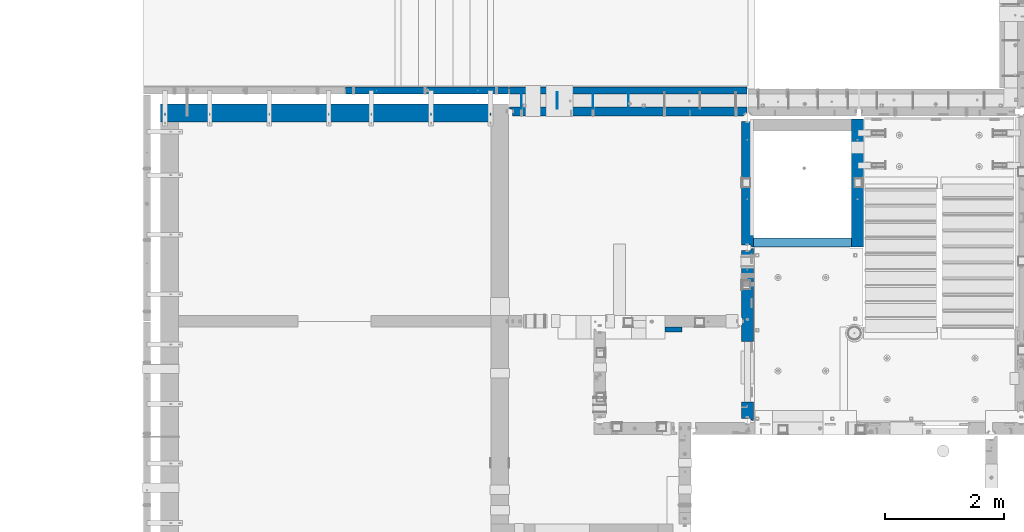
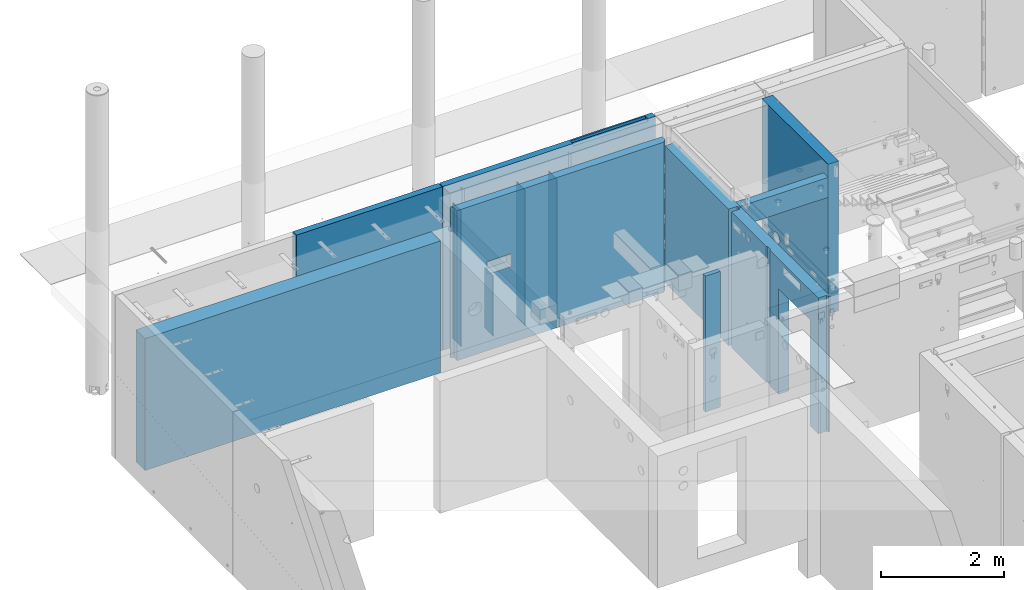
# One storey, part 175 of 264: 13 walls, 6 elements without a shape of their own.
"""IFC2X3 building model written with IfcOpenShell, lengths in millimetres."""

from ifc_helpers import new_model, si_unit, frame, origin_with_axes, place, context, subcontext, project, spatial, faceted_brep, material, type_object, element, aggregate, save


model = new_model("IFC2X3")

# Units and contexts
model_context = context("Model", 3, precision=1e-05, world=origin_with_axes())
body_context = subcontext(model_context, "Body", "Model", "MODEL_VIEW")
ifc_project = project(units=[si_unit("LENGTHUNIT", "METRE", prefix="MILLI"), si_unit("AREAUNIT", "SQUARE_METRE"), si_unit("VOLUMEUNIT", "CUBIC_METRE"), si_unit("MASSUNIT", "GRAM", prefix="KILO"), si_unit("TIMEUNIT", "SECOND"), si_unit("PLANEANGLEUNIT", "RADIAN"), si_unit("SOLIDANGLEUNIT", "STERADIAN"), si_unit("THERMODYNAMICTEMPERATUREUNIT", "DEGREE_CELSIUS"), si_unit("LUMINOUSINTENSITYUNIT", "LUMEN")], contexts=[model_context])

# Site, building, storey
site_placement = place(None, origin_with_axes())
site = spatial("IfcSite", under=ifc_project, at=site_placement, CompositionType="ELEMENT")
building_placement = place(site_placement, origin_with_axes())
building = spatial("IfcBuilding", under=site, at=building_placement, CompositionType="ELEMENT")
storey_placement = place(building_placement, origin_with_axes())
storey = spatial("IfcBuildingStorey", under=building, at=storey_placement, Name="K", CompositionType="ELEMENT", Elevation=0.0)

# Assembly, walls
assembly_1_placement = place(storey_placement, origin_with_axes())
assembly_1 = element("IfcElementAssembly", 1, at=assembly_1_placement, inside=storey, AssemblyPlace="NOTDEFINED", PredefinedType="REINFORCEMENT_UNIT")
ifc_material_1 = material(Name="CONCRETE/C25/30")
wall_type_1 = type_object("IfcWallType", PredefinedType="NOTDEFINED")
wall_1_placement = place(assembly_1_placement, frame((17710.0, 18214.9992663657, 80112.5), z_axis=(0.0, 0.0, 1.0), x_axis=(0.0, 1.0, 0.0)))
wall_1 = element("IfcWall", 2, at=wall_1_placement, type_object=wall_type_1, material=ifc_material_1, context=body_context, shape_type="Brep", body=[
    faceted_brep([(2120.00073363433, -57.0000000000036, 1357.5), (2120.00073363433, -57.0000000000036, -1357.5), (2120.00073363433, 100.0, -1357.5), (2120.00073363433, 100.0, 1357.5), (2165.00073363433, -70.0000000000036, 1357.5), (2165.00073363433, -70.0000000000036, -1357.5), (45.0, 100.0, 1357.5), (45.0, 100.0, -1357.5), (45.0, -57.0, -1357.5), (45.0, -57.0, 1357.5), (15.0, -70.0, 1357.5), (15.0, -70.0000000000036, -1357.5), (15.0, -100.0, -1357.5), (15.0, -100.0, 1357.5), (2165.00073363433, -100.0, -1357.5), (2165.00073363433, -100.0, 1357.5)], [[[0, 1, 2, 3]], [[4, 5, 1, 0]], [[6, 7, 8, 9]], [[10, 9, 8, 11]], [[12, 13, 10, 11]], [[13, 12, 14, 15]], [[3, 6, 9, 10, 13, 15, 4, 0]], [[7, 6, 3, 2]], [[14, 12, 11, 8, 7, 2, 1, 5]], [[15, 14, 5, 4]]]),
])
wall_type_2 = type_object("IfcWallType", PredefinedType="NOTDEFINED")
wall_2_placement = place(assembly_1_placement, frame((19559.999681647, 18229.9992663657, 80242.5), z_axis=(0.0, 0.0, 1.0), x_axis=(0.0, 1.0, 0.0)))
wall_2 = element("IfcWall", 3, at=wall_2_placement, type_object=wall_type_2, material=ifc_material_1, context=body_context, shape_type="Brep", body=[
    faceted_brep([(1766.59369624284, -100.0, -1008.38190451026), (1766.59369624284, 100.0, -1008.38190451026), (1756.60365399238, 100.0, -1032.5), (1756.60365399238, -100.0, -1032.5), (1740.71179173259, 100.0, -1053.21067811866), (1740.71179173259, -100.0, -1053.21067811866), (1720.00111361394, 100.0, -1069.10254037844), (1720.00111361394, -100.0, -1069.10254037844), (1695.88301812419, 100.0, -1079.0925826289), (1695.88301812419, -100.0, -1079.0925826289), (1670.00111361394, 100.0, -1082.5), (1670.00111361394, -100.0, -1082.5), (1644.11920910368, 100.0, -1079.0925826289), (1644.11920910368, -100.0, -1079.0925826289), (1620.00111361394, 100.0, -1069.10254037844), (1620.00111361394, -100.0, -1069.10254037844), (1599.29043549528, 100.0, -1053.21067811866), (1599.29043549528, -100.0, -1053.21067811866), (1583.39857323549, 100.0, -1032.5), (1583.39857323549, -100.0, -1032.5), (1573.40853098503, 100.0, -1008.38190451026), (1573.40853098503, -100.0, -1008.38190451026), (1570.00111361394, 100.0, -982.5), (1570.00111361394, -100.0, -982.5), (1573.40853098503, 100.0, -956.618095489743), (1573.40853098503, -100.0, -956.618095489743), (1583.39857323549, 100.0, -932.5), (1583.39857323549, -100.0, -932.5), (1599.29043549528, 100.0, -911.789321881341), (1599.29043549528, -100.0, -911.789321881341), (1620.00111361394, 100.0, -895.897459621556), (1620.00111361394, -100.0, -895.897459621556), (1644.11920910368, 100.0, -885.907417371098), (1644.11920910368, -100.0, -885.907417371098), (1670.00111361394, 100.0, -882.5), (1670.00111361394, -100.0, -882.5), (1695.88301812419, 100.0, -885.907417371098), (1695.88301812419, -100.0, -885.907417371098), (1720.00111361394, 100.0, -895.897459621556), (1720.00111361394, -100.0, -895.897459621556), (1740.71179173259, 100.0, -911.789321881341), (1740.71179173259, -100.0, -911.789321881341), (1756.60365399238, 100.0, -932.5), (1756.60365399238, -100.0, -932.5), (1766.59369624284, 100.0, -956.618095489743), (1766.59369624284, -100.0, -956.618095489743), (1770.00111361394, 100.0, -982.5), (1770.00111361394, -100.0, -982.5), (2010.00546574604, -0.100182625668822, -27.5), (1810.00546574604, -0.100182625668822, -27.5), (1810.00546574604, -0.100182625668822, -137.5), (2010.00546574604, -0.100182625668822, -137.5), (1785.00546574604, -100.100182625669, 7.5), (2035.00546574604, -100.100182625669, 7.5), (1785.00546574604, -100.100182625669, -137.5), (2035.00546574604, -100.100182625669, -137.5), (1470.00546574604, -0.100182625668822, -27.5), (1270.00546574604, -0.100182625668822, -27.5), (1270.00546574604, -0.100182625668822, -137.5), (1470.00546574604, -0.100182625668822, -137.5), (1245.00546574604, -100.100182625669, 7.5), (1495.00546574604, -100.100182625669, 7.5), (1245.00546574604, -100.100182625669, -137.5), (1495.00546574604, -100.100182625669, -137.5), (0.0, -100.0, 1487.5), (0.0, -100.0, -1487.5), (2150.00073363433, -100.0, -1487.5), (2150.00073363433, -100.0, 1487.5), (0.0, 100.0, 1487.5), (2150.00073363433, 100.0, 1487.5), (0.0, 100.0, -1487.5), (2150.00073363433, 100.0, -1487.5)], [[[0, 1, 2, 3]], [[3, 2, 4, 5]], [[5, 4, 6, 7]], [[7, 6, 8, 9]], [[9, 8, 10, 11]], [[11, 10, 12, 13]], [[13, 12, 14, 15]], [[15, 14, 16, 17]], [[17, 16, 18, 19]], [[19, 18, 20, 21]], [[21, 20, 22, 23]], [[23, 22, 24, 25]], [[25, 24, 26, 27]], [[27, 26, 28, 29]], [[29, 28, 30, 31]], [[31, 30, 32, 33]], [[33, 32, 34, 35]], [[35, 34, 36, 37]], [[37, 36, 38, 39]], [[39, 38, 40, 41]], [[41, 40, 42, 43]], [[43, 42, 44, 45]], [[45, 44, 46, 47]], [[47, 46, 1, 0]], [[48, 49, 50, 51]], [[52, 49, 48, 53]], [[54, 50, 49, 52]], [[55, 51, 50, 54]], [[53, 48, 51, 55]], [[56, 57, 58, 59]], [[60, 57, 56, 61]], [[62, 58, 57, 60]], [[63, 59, 58, 62]], [[61, 56, 59, 63]], [[64, 65, 66, 67], [3, 5, 7, 9, 11, 13, 15, 17, 19, 21, 23, 25, 27, 29, 31, 33, 35, 37, 39, 41, 43, 45, 47, 0], [62, 60, 61, 63], [54, 52, 53, 55]], [[68, 64, 67, 69]], [[65, 64, 68, 70]], [[65, 70, 71, 66]], [[67, 66, 71, 69]], [[70, 68, 69, 71], [42, 40, 38, 36, 34, 32, 30, 28, 26, 24, 22, 20, 18, 16, 14, 12, 10, 8, 6, 4, 2, 1, 46, 44]]]),
])
wall_type_3 = type_object("IfcWallType", PredefinedType="NOTDEFINED")
wall_3_placement = place(assembly_1_placement, frame((17809.9999105288, 18304.9992663657, 81272.5), z_axis=(0.0, 0.0, 1.0), x_axis=(1.0, 0.0, 0.0)))
wall_3 = element("IfcWall", 4, at=wall_3_placement, type_object=wall_type_3, material=ifc_material_1, context=body_context, shape_type="Brep", body=[
    faceted_brep([(0.0, 75.0, -197.5), (0.0, 75.0, 197.5), (1649.99961853027, 75.0, 197.5), (1649.99961853027, 75.0, -197.5), (0.0, -75.0, 197.5), (1649.99961853027, -75.0, 197.5), (0.0, -75.0, -197.5), (1649.99961853027, -75.0, -197.5)], [[[0, 1, 2, 3]], [[1, 4, 5, 2]], [[4, 6, 7, 5]], [[6, 0, 3, 7]], [[5, 7, 3, 2]], [[6, 4, 1, 0]]]),
])
aggregate(assembly_1, [wall_1, wall_2, wall_3])

assembly_2_placement = place(storey_placement, origin_with_axes())
assembly_2 = element("IfcElementAssembly", 5, at=assembly_2_placement, inside=storey, AssemblyPlace="NOTDEFINED", PredefinedType="REINFORCEMENT_UNIT")
ifc_material_2 = material(Name="Undefined")
wall_type_4 = type_object("IfcWallType", PredefinedType="NOTDEFINED")
wall_4_placement = place(assembly_2_placement, frame((15715.0002441406, 20549.9951872276, 79990.0), z_axis=(0.0, 0.0, 1.0), x_axis=(0.0, 1.0, 0.0)))
wall_4 = element("IfcWall", 6, at=wall_4_placement, type_object=wall_type_4, material=ifc_material_2, Name="(PD)", context=body_context, shape_type="Brep", body=[
    faceted_brep([(0.0, 5.0, -1350.0), (0.0, 5.0, 1350.0), (280.0, 5.0, 1350.0), (280.0, 5.0, -1350.0), (0.0, -5.0, 1350.0), (280.0, -5.0, 1350.0), (0.0, -5.0, -1350.0), (280.0, -5.0, -1350.0)], [[[0, 1, 2, 3]], [[1, 4, 5, 2]], [[4, 6, 7, 5]], [[6, 0, 3, 7]], [[5, 7, 3, 2]], [[6, 4, 1, 0]]]),
])
wall_5_placement = place(assembly_2_placement, frame((15115.0002441406, 20549.9951872276, 79990.0), z_axis=(0.0, 0.0, 1.0), x_axis=(0.0, 1.0, 0.0)))
wall_5 = element("IfcWall", 7, at=wall_5_placement, type_object=wall_type_4, material=ifc_material_2, Name="(PD)", context=body_context, shape_type="Brep", body=[
    faceted_brep([(0.0, 5.0, -1350.0), (0.0, 5.0, 1350.0), (280.0, 5.0, 1350.0), (280.0, 5.0, -1350.0), (0.0, -5.0, 1350.0), (280.0, -5.0, 1350.0), (0.0, -5.0, -1350.0), (280.0, -5.0, -1350.0)], [[[0, 1, 2, 3]], [[1, 4, 5, 2]], [[4, 6, 7, 5]], [[6, 0, 3, 7]], [[5, 7, 3, 2]], [[6, 4, 1, 0]]]),
])
wall_6_placement = place(assembly_2_placement, frame((13915.0002441406, 20549.9951872276, 79990.0), z_axis=(0.0, 0.0, 1.0), x_axis=(0.0, 1.0, 0.0)))
wall_6 = element("IfcWall", 8, at=wall_6_placement, type_object=wall_type_4, material=ifc_material_2, Name="(PD)", context=body_context, shape_type="Brep", body=[
    faceted_brep([(0.0, 5.0, -1350.0), (0.0, 5.0, 1350.0), (280.0, 5.0, 1350.0), (280.0, 5.0, -1350.0), (0.0, -5.0, 1350.0), (280.0, -5.0, 1350.0), (0.0, -5.0, -1350.0), (280.0, -5.0, -1350.0)], [[[0, 1, 2, 3]], [[1, 4, 5, 2]], [[4, 6, 7, 5]], [[6, 0, 3, 7]], [[5, 7, 3, 2]], [[6, 4, 1, 0]]]),
])
wall_type_5 = type_object("IfcWallType", PredefinedType="NOTDEFINED")
wall_7_placement = place(assembly_2_placement, frame((14515.0002441407, 20549.9951872276, 79240.0), z_axis=(0.0, 0.0, 1.0), x_axis=(0.0, 1.0, 0.0)))
wall_7 = element("IfcWall", 9, at=wall_7_placement, type_object=wall_type_5, material=ifc_material_2, Name="(PD)", context=body_context, shape_type="Brep", body=[
    faceted_brep([(0.0, 5.0, -600.0), (0.0, 5.0, 600.0), (280.000000000018, 5.0, 600.0), (280.000000000018, 5.0, -600.0), (0.0, -5.0, 600.0), (280.000000000018, -5.0, 600.0), (0.0, -5.0, -600.0), (280.000000000018, -5.0, -600.0)], [[[0, 1, 2, 3]], [[1, 4, 5, 2]], [[4, 6, 7, 5]], [[6, 0, 3, 7]], [[5, 7, 3, 2]], [[6, 4, 1, 0]]]),
])

# Assembly, wall
assembly_3_placement = place(storey_placement, origin_with_axes())
assembly_3 = element("IfcElementAssembly", 10, at=assembly_3_placement, inside=storey, AssemblyPlace="NOTDEFINED", PredefinedType="REINFORCEMENT_UNIT")
ifc_material_3 = material(Name="CONCRETE/C30/37")
wall_type_6 = type_object("IfcWallType", PredefinedType="NOTDEFINED")
wall_8_placement = place(assembly_3_placement, frame((16329.9998368278, 16840.0034224637, 80122.5), z_axis=(0.0, 0.0, 1.0), x_axis=(1.0, 0.0, 0.0)))
wall_8 = element("IfcWall", 11, at=wall_8_placement, type_object=wall_type_6, material=ifc_material_3, context=body_context, shape_type="Brep", body=[
    faceted_brep([(0.0, 40.0, -1347.5), (0.0, 40.0, 1347.5), (279.999568728097, 40.0, 1347.5), (279.999568728097, 40.0, -1347.5), (0.0, -40.0, 1347.5), (279.999568728097, -40.0, 1347.5), (0.0, -40.0, -1347.5), (279.999568728097, -40.0, -1347.5)], [[[0, 1, 2, 3]], [[1, 4, 5, 2]], [[4, 6, 7, 5]], [[6, 0, 3, 7]], [[5, 7, 3, 2]], [[6, 4, 1, 0]]]),
])
aggregate(assembly_3, [wall_8])

assembly_4_placement = place(storey_placement, origin_with_axes())
assembly_4 = element("IfcElementAssembly", 12, at=assembly_4_placement, inside=storey, AssemblyPlace="NOTDEFINED", PredefinedType="REINFORCEMENT_UNIT")
wall_type_7 = type_object("IfcWallType", PredefinedType="NOTDEFINED")
wall_9_placement = place(assembly_4_placement, frame((17710.0, 15280.0, 80122.5), z_axis=(0.0, 0.0, 1.0), x_axis=(0.0, 1.0, 0.0)))
wall_9 = element("IfcWall", 13, at=wall_9_placement, type_object=wall_type_7, material=ifc_material_1, context=body_context, shape_type="Brep", body=[
    faceted_brep([(1199.12963611364, -100.0, 1137.5), (1199.12963611364, 100.0, 1137.5), (649.129636113645, 100.0, 1137.5), (649.129636113645, -100.0, 1137.5), (649.129636113645, 100.0, 1287.5), (649.129636113645, -100.0, 1287.5), (1199.12963611364, 100.0, 1287.5), (1199.12963611364, -100.0, 1287.5), (2889.99926636568, -57.0, 1347.5), (2889.99926636568, -57.0, -1347.5), (2889.99926636568, 100.0, -1347.5), (2889.99926636568, 100.0, 1347.5), (2919.99926636568, -70.0, 1347.5), (2919.99926636568, -70.0, -1347.5), (2919.99926636568, -100.0, 1347.5), (2919.99926636568, -100.0, -1347.5), (29.9999685214098, -100.0, -1347.5), (29.9999685214098, -100.0, 1347.5), (29.9999999999982, -67.7058823529405, 1347.5), (29.9999999999982, -67.7058823529405, -1347.5), (64.9999999999982, 100.0, 1347.5), (64.9999999999982, 100.0, -1347.5), (64.9999999999982, -57.0, -1347.5), (64.9999999999982, -57.0, 1347.5), (340.000303685665, 100.0, -1347.5), (340.000303685665, -100.0, -1347.5), (340.000303685665, 100.0, 752.5), (340.000303685665, -100.0, 752.5), (1360.00030368567, 100.0, 752.5), (1360.00030368567, -100.0, 752.5), (1360.00030368567, 100.0, -1347.5), (1360.00030368567, -100.0, -1347.5), (2356.95516073685, -100.0, 1162.80733729461), (2356.95516073685, 100.0, 1162.80733729461), (2359.9999794364, 100.0, 1147.5), (2359.9999794364, -100.0, 1147.5), (2348.28425068386, -100.0, 1175.78427124747), (2348.28425068386, 100.0, 1175.78427124747), (2335.307316731, -100.0, 1184.45518130045), (2335.307316731, 100.0, 1184.45518130045), (2319.9999794364, -100.0, 1187.5), (2319.9999794364, 100.0, 1187.5), (2304.6926421418, -100.0, 1184.45518130045), (2304.6926421418, 100.0, 1184.45518130045), (2291.71570818893, -100.0, 1175.78427124747), (2291.71570818893, 100.0, 1175.78427124747), (2283.04479813595, -100.0, 1162.80733729461), (2283.04479813595, 100.0, 1162.80733729461), (2279.9999794364, -100.0, 1147.5), (2279.9999794364, 100.0, 1147.5), (2283.04479813595, -100.0, 1132.19266270539), (2283.04479813595, 100.0, 1132.19266270539), (2291.71570818893, -100.0, 1119.21572875253), (2291.71570818893, 100.0, 1119.21572875253), (2304.6926421418, -100.0, 1110.54481869955), (2304.6926421418, 100.0, 1110.54481869955), (2319.9999794364, -100.0, 1107.5), (2319.9999794364, 100.0, 1107.5), (2335.307316731, -100.0, 1110.54481869955), (2335.307316731, 100.0, 1110.54481869955), (2348.28425068386, -100.0, 1119.21572875253), (2348.28425068386, 100.0, 1119.21572875253), (2356.95516073685, -100.0, 1132.19266270539), (2356.95516073685, 100.0, 1132.19266270539), (2498.28425068386, -100.0, 1119.21572875253), (2485.307316731, -100.0, 1110.54481869955), (2469.9999794364, -100.0, 1107.5), (2454.6926421418, -100.0, 1110.54481869955), (2441.71570818893, -100.0, 1119.21572875253), (2433.04479813595, -100.0, 1132.19266270539), (2429.9999794364, -100.0, 1147.5), (2433.04479813595, -100.0, 1162.80733729461), (2441.71570818893, -100.0, 1175.78427124747), (2454.6926421418, -100.0, 1184.45518130045), (2469.9999794364, -100.0, 1187.5), (2485.307316731, -100.0, 1184.45518130045), (2498.28425068386, -100.0, 1175.78427124747), (2506.95516073685, -100.0, 1162.80733729461), (2509.9999794364, -100.0, 1147.5), (2506.95516073685, -100.0, 1132.19266270539), (2498.28425068386, 100.0, 1175.78427124747), (2506.95516073685, 100.0, 1162.80733729461), (2485.307316731, 100.0, 1184.45518130045), (2469.9999794364, 100.0, 1187.5), (2454.6926421418, 100.0, 1184.45518130045), (2441.71570818893, 100.0, 1175.78427124747), (2433.04479813595, 100.0, 1162.80733729461), (2429.9999794364, 100.0, 1147.5), (2433.04479813595, 100.0, 1132.19266270539), (2441.71570818893, 100.0, 1119.21572875253), (2454.6926421418, 100.0, 1110.54481869955), (2469.9999794364, 100.0, 1107.5), (2485.307316731, 100.0, 1110.54481869955), (2498.28425068386, 100.0, 1119.21572875253), (2506.95516073685, 100.0, 1132.19266270539), (2509.9999794364, 100.0, 1147.5), (1765.00000368528, 100.0, -1347.5), (1765.00000368528, 100.0, 1347.5), (1635.0, 100.0, 1347.5), (1751.9999991369, 80.0000000823784, 1347.5), (1648.00000041054, 79.9999993903439, 1347.5), (1751.9999991369, 80.0000000823784, -1347.5), (1648.00000041054, 79.9999993903439, -1347.5), (1635.0, 100.0, -1347.5)], [[[0, 1, 2, 3]], [[3, 2, 4, 5]], [[5, 4, 6, 7]], [[7, 6, 1, 0]], [[8, 9, 10, 11]], [[12, 13, 9, 8]], [[14, 15, 13, 12]], [[16, 17, 18, 19]], [[20, 21, 22, 23]], [[18, 23, 22, 19]], [[21, 24, 25, 16, 19, 22]], [[25, 24, 26, 27]], [[27, 26, 28, 29]], [[29, 28, 30, 31]], [[32, 33, 34, 35]], [[36, 37, 33, 32]], [[38, 39, 37, 36]], [[40, 41, 39, 38]], [[42, 43, 41, 40]], [[44, 45, 43, 42]], [[46, 47, 45, 44]], [[48, 49, 47, 46]], [[50, 51, 49, 48]], [[52, 53, 51, 50]], [[54, 55, 53, 52]], [[56, 57, 55, 54]], [[58, 59, 57, 56]], [[60, 61, 59, 58]], [[62, 63, 61, 60]], [[35, 34, 63, 62]], [[15, 14, 17, 16, 25, 27, 29, 31], [3, 5, 7, 0], [64, 65, 66, 67, 68, 69, 70, 71, 72, 73, 74, 75, 76, 77, 78, 79], [60, 58, 56, 54, 52, 50, 48, 46, 44, 42, 40, 38, 36, 32, 35, 62]], [[76, 80, 81, 77]], [[75, 82, 80, 76]], [[74, 83, 82, 75]], [[73, 84, 83, 74]], [[72, 85, 84, 73]], [[71, 86, 85, 72]], [[70, 87, 86, 71]], [[69, 88, 87, 70]], [[68, 89, 88, 69]], [[67, 90, 89, 68]], [[66, 91, 90, 67]], [[65, 92, 91, 66]], [[64, 93, 92, 65]], [[79, 94, 93, 64]], [[78, 95, 94, 79]], [[77, 81, 95, 78]], [[11, 10, 96, 97], [80, 82, 83, 84, 85, 86, 87, 88, 89, 90, 91, 92, 93, 94, 95, 81], [37, 39, 41, 43, 45, 47, 49, 51, 53, 55, 57, 59, 61, 63, 34, 33]], [[98, 20, 23, 18, 17, 14, 12, 8, 11, 97, 99, 100]], [[99, 101, 102, 100]], [[97, 96, 101, 99]], [[10, 9, 13, 15, 31, 30, 103, 102, 101, 96]], [[100, 102, 103, 98]], [[30, 28, 26, 24, 21, 20, 98, 103], [2, 1, 6, 4]]]),
])
aggregate(assembly_4, [wall_9])

# Wall
wall_type_8 = type_object("IfcWallType", PredefinedType="NOTDEFINED")
wall_10_placement = place(assembly_2_placement, frame((13715.0034534813, 20859.9999956849, 80115.0), z_axis=(0.0, 0.0, 1.0), x_axis=(1.0, 0.0, 0.0)))
wall_10 = element("IfcWall", 14, at=wall_10_placement, type_object=wall_type_8, material=ifc_material_3, context=body_context, shape_type="Brep", body=[
    faceted_brep([(3989.99652923887, 60.0000000000073, 1385.0), (1.81898940354586e-12, 60.0000000000036, 1385.0), (-0.00346500129853666, 40.0000043141226, 1385.0), (3989.99653499853, 40.0011534341211, 1385.0), (-0.00346500129853666, 40.0000043141226, 1485.0), (3989.99653499853, 40.0011534341211, 1485.0), (3989.99652923853, 60.0011534341211, 1485.0), (1.81898940354586e-12, 60.0000000000036, 1485.0), (502.572165045003, 60.0000000000073, -769.235467389692), (502.572199605003, -59.9999999999927, -769.235467389692), (511.817080139928, -59.9999999999964, -742.815116744532), (511.817045579928, 60.0000000000036, -742.815116744532), (487.679991865703, 60.0000000000036, -792.936225232348), (487.680026425704, -59.9999999999964, -792.936225232348), (467.887281789539, 60.0000000000073, -812.728935308507), (467.887316349539, -59.9999999999927, -812.728935308507), (444.186523946893, 60.0000000000073, -827.621108487801), (444.186558506894, -59.9999999999927, -827.621108487801), (417.766173301736, 60.0000000000036, -836.865989022728), (417.766207861736, -59.9999999999964, -836.865989022728), (389.951056557196, 60.0000000000036, -840.0), (389.951091117196, -59.9999999999927, -840.0), (362.135939812657, 60.0000000000073, -836.865989022728), (362.135974372657, -59.9999999999927, -836.865989022728), (335.715589167497, 60.0000000000036, -827.621108487801), (335.715623727498, -59.9999999999964, -827.621108487801), (312.014831324852, 60.0000000000073, -812.728935308507), (312.014865884852, -59.9999999999927, -812.728935308507), (292.222121248687, 60.0000000000073, -792.936225232348), (292.222155808688, -59.9999999999927, -792.936225232348), (277.329948069388, 60.0000000000073, -769.235467389692), (277.329982629388, -59.9999999999927, -769.235467389692), (268.085067534463, 60.0000000000073, -742.815116744532), (268.085102094463, -59.9999999999927, -742.815116744532), (264.951056557191, 60.0000000000073, -715.0), (264.951091117191, -59.9999999999927, -715.0), (268.085067534463, 60.0000000000073, -687.184883255468), (268.085102094463, -59.9999999999927, -687.184883255468), (277.329948069388, 60.0000000000073, -660.764532610308), (277.329982629388, -59.9999999999927, -660.764532610308), (292.222121248687, 60.0000000000073, -637.063774767652), (292.222155808688, -59.9999999999927, -637.063774767652), (312.014831324852, 60.0000000000073, -617.271064691493), (312.014865884852, -59.9999999999927, -617.271064691493), (335.715589167497, 60.0000000000036, -602.378891512199), (335.715623727498, -59.9999999999964, -602.378891512199), (362.135939812657, 60.0000000000073, -593.134010977272), (362.135974372657, -59.9999999999927, -593.134010977272), (389.951056557196, 60.0000000000036, -590.0), (389.951091117196, -59.9999999999927, -590.0), (417.766173301736, 60.0000000000036, -593.134010977272), (417.766207861736, -59.9999999999964, -593.134010977272), (444.186523946893, 60.0000000000073, -602.378891512199), (444.186558506894, -59.9999999999927, -602.378891512199), (467.887281789539, 60.0000000000073, -617.271064691493), (467.887316349539, -59.9999999999927, -617.271064691493), (487.679991865703, 60.0000000000036, -637.063774767652), (487.680026425704, -59.9999999999964, -637.063774767652), (502.572165045003, 60.0000000000073, -660.764532610308), (502.572199605003, -59.9999999999927, -660.764532610308), (511.817045579928, 60.0000000000036, -687.184883255468), (511.817080139928, -59.9999999999964, -687.184883255468), (514.951056557202, 60.0000000000073, -715.0), (514.951091117202, -59.9999999999927, -715.0), (3.63797880709171e-12, -59.9999999999927, -1625.0), (1.81898940354586e-12, 60.0000000000036, -1625.0), (3989.99652923887, 60.0000000000073, -1625.0), (3989.99656379887, -59.9999999999927, -1625.0), (1.81898940354586e-12, 60.0000000000036, 1625.0), (3989.99652923887, 60.0000000000073, 1625.0), (3.63797880709171e-12, -59.9999999999927, 1625.0), (3989.99656379887, -59.9999999999927, 1625.0), (2439.9963243327, -59.9999999999964, 1625.0), (2439.99629898878, 27.9996999539726, 1625.0), (3849.99629898873, 28.000106033971, 1625.0), (3849.99632433276, -59.9999999999964, 1625.0), (2439.99629898878, 27.9996999539726, 1575.0), (3849.99629898873, 28.000106033971, 1575.0), (2439.9963243327, -59.9999999999927, 1575.0), (3849.99632433276, -59.9999999999964, 1575.0), (614.99667674953, -59.9999999999927, -105.0), (614.99667674953, -59.9999999999927, 145.0), (1064.99667674955, -59.9999999999927, 145.0), (1064.99667674955, -59.9999999999927, -105.0), (1064.99664218955, 60.0000000000036, -105.0), (1064.99664218955, 60.0000000000036, 145.0), (614.99664218953, 60.0000000000036, -105.0), (614.99664218953, 60.0000000000036, 145.0)], [[[0, 1, 2, 3]], [[3, 2, 4, 5]], [[6, 5, 4, 7]], [[8, 9, 10, 11]], [[12, 13, 9, 8]], [[14, 15, 13, 12]], [[16, 17, 15, 14]], [[18, 19, 17, 16]], [[20, 21, 19, 18]], [[22, 23, 21, 20]], [[24, 25, 23, 22]], [[26, 27, 25, 24]], [[28, 29, 27, 26]], [[30, 31, 29, 28]], [[32, 33, 31, 30]], [[34, 35, 33, 32]], [[36, 37, 35, 34]], [[38, 39, 37, 36]], [[40, 41, 39, 38]], [[42, 43, 41, 40]], [[44, 45, 43, 42]], [[46, 47, 45, 44]], [[48, 49, 47, 46]], [[50, 51, 49, 48]], [[52, 53, 51, 50]], [[54, 55, 53, 52]], [[56, 57, 55, 54]], [[58, 59, 57, 56]], [[60, 61, 59, 58]], [[62, 63, 61, 60]], [[11, 10, 63, 62]], [[64, 65, 66, 67]], [[68, 69, 6, 7]], [[2, 1, 65, 64, 70, 68, 7, 4]], [[71, 69, 68, 70, 72, 73, 74, 75]], [[73, 76, 77, 74]], [[72, 78, 76, 73]], [[79, 77, 76, 78]], [[74, 77, 79, 75]], [[78, 72, 70, 64, 67, 71, 75, 79], [9, 13, 15, 17, 19, 21, 23, 25, 27, 29, 31, 33, 35, 37, 39, 41, 43, 45, 47, 49, 51, 53, 55, 57, 59, 61, 63, 10], [80, 81, 82, 83]], [[84, 83, 82, 85]], [[86, 80, 83, 84]], [[87, 81, 80, 86]], [[85, 82, 81, 87]], [[66, 65, 1, 0], [86, 84, 85, 87], [58, 56, 54, 52, 50, 48, 46, 44, 42, 40, 38, 36, 34, 32, 30, 28, 26, 24, 22, 20, 18, 16, 14, 12, 8, 11, 62, 60]], [[69, 71, 67, 66, 0, 3, 5, 6]]]),
])

# Assembly, wall
assembly_5_placement = place(storey_placement, origin_with_axes())
assembly_5 = element("IfcElementAssembly", 15, at=assembly_5_placement, inside=storey, AssemblyPlace="NOTDEFINED", PredefinedType="REINFORCEMENT_UNIT")
ifc_material_4 = material(Name="CONCRETE/C40/50")
wall_11_placement = place(assembly_5_placement, frame((10960.0, 20860.0, 80115.0), z_axis=(0.0, 0.0, 1.0), x_axis=(1.0, 0.0, 0.0)))
wall_11 = element("IfcWall", 16, at=wall_11_placement, type_object=wall_type_8, material=ifc_material_4, context=body_context, shape_type="Brep", body=[
    faceted_brep([(2740.0, 60.0, 1421.19462326776), (1076.25557595991, 60.0000000913351, 381.569675241713), (1076.25557595991, 40.000000099797, 381.569675241713), (2740.0, 40.000000099797, 1421.19462326776), (1074.1120669287, 60.0, 385.0), (1074.1120669287, 40.0, 385.0), (1075.0, 40.0, 385.0), (1075.0, 40.0, 485.0), (1053.07064582137, 40.0, 485.0), (2740.0, 40.000000099797, 1539.11252883593), (2740.0, 60.000000099797, 1539.11252883593), (1053.07064582135, 60.0, 485.0), (1.81898940354586e-12, 40.0, 385.0), (0.0, 60.0, 385.0), (1.81898940354586e-12, 60.0000000000036, -1625.0), (3.63797880709171e-12, -59.9999999999927, -1625.0), (3.63797880709171e-12, -59.9999999999927, 1625.0), (1.81898940354586e-12, 60.0000000000036, 1625.0), (0.0, 60.0, 485.0), (1.81898940354586e-12, 40.0, 485.0), (2740.0, 60.0, -1625.0), (2740.0, -60.0, -1625.0), (2740.0, -60.0, 1625.0), (2740.0, 60.0, 1625.0)], [[[0, 1, 2, 3]], [[4, 5, 2, 1]], [[3, 2, 5, 6, 7, 8, 9]], [[10, 9, 8, 11]], [[12, 13, 14, 15, 16, 17, 18, 19]], [[15, 14, 20, 21]], [[16, 15, 21, 22]], [[17, 16, 22, 23]], [[18, 17, 23, 10, 11]], [[19, 18, 11, 8]], [[19, 8, 7, 6, 5, 12]], [[13, 12, 5, 4]], [[20, 14, 13, 4, 1, 0]], [[23, 22, 21, 20, 0, 3, 9, 10]]]),
])
aggregate(assembly_5, [wall_11])

# Wall
wall_type_9 = type_object("IfcWallType", PredefinedType="NOTDEFINED")
wall_12_placement = place(assembly_2_placement, frame((13700.0033944466, 20505.0, 79980.0), z_axis=(0.0, 0.0, 1.0), x_axis=(1.0, 0.0, 0.0)))
wall_12 = element("IfcWall", 17, at=wall_12_placement, type_object=wall_type_9, material=ifc_material_1, context=body_context, shape_type="Brep", body=[
    faceted_brep([(526.817100294633, 75.0, -552.184883255468), (526.817143494633, -75.0000000000036, -552.184883255468), (517.572262959708, -75.0000000000036, -525.764532610308), (517.572219759708, 75.0, -525.764532610308), (502.680089780408, -75.0000000000036, -502.063774767652), (502.680046580408, 75.0, -502.063774767652), (482.887379704243, -75.0000000000036, -482.271064691493), (482.887336504244, 75.0, -482.271064691493), (459.186621861598, -75.0000000000036, -467.378891512199), (459.186578661598, 75.0, -467.378891512199), (432.76627121644, -75.0000000000036, -458.134010977272), (432.76622801644, 75.0, -458.134010977272), (404.951154471901, -75.0000000000036, -455.0), (404.951111271899, 75.0000000000036, -455.0), (377.13603772736, -75.0000000000036, -458.134010977272), (377.13599452736, 75.0, -458.134010977272), (350.715687082202, -75.0000000000036, -467.378891512199), (350.715643882202, 75.0000000000036, -467.378891512199), (327.014929239556, -75.0000000000036, -482.271064691493), (327.014886039557, 75.0, -482.271064691493), (307.222219163392, -75.0000000000036, -502.063774767652), (307.222175963392, 75.0, -502.063774767652), (292.33004598409, -75.0000000000036, -525.764532610308), (292.330002784091, 75.0, -525.764532610308), (283.085165449167, -75.0000000000036, -552.184883255468), (283.085122249167, 75.0, -552.184883255468), (279.951154471895, -75.0000000000036, -580.0), (279.951111271896, 75.0, -580.0), (283.085165449167, -75.0000000000036, -607.815116744532), (283.085122249167, 75.0, -607.815116744532), (292.33004598409, -75.0000000000036, -634.235467389692), (292.330002784091, 75.0, -634.235467389692), (307.222219163392, -75.0000000000036, -657.936225232348), (307.222175963392, 75.0, -657.936225232348), (327.014929239556, -75.0000000000036, -677.728935308507), (327.014886039557, 75.0, -677.728935308507), (350.715687082202, -75.0000000000036, -692.621108487801), (350.715643882202, 75.0000000000036, -692.621108487801), (377.13603772736, -75.0000000000036, -701.865989022728), (377.13599452736, 75.0, -701.865989022728), (404.951154471901, -75.0000000000036, -705.0), (404.951111271899, 75.0000000000036, -705.0), (432.76627121644, -75.0000000000036, -701.865989022728), (432.76622801644, 75.0, -701.865989022728), (459.186621861598, -75.0000000000036, -692.621108487801), (459.186578661598, 75.0, -692.621108487801), (482.887379704243, -75.0000000000036, -677.728935308507), (482.887336504244, 75.0, -677.728935308507), (502.680089780408, -75.0000000000036, -657.936225232348), (502.680046580408, 75.0, -657.936225232348), (517.572262959708, -75.0000000000036, -634.235467389692), (517.572219759708, 75.0, -634.235467389692), (526.817143494633, -75.0000000000036, -607.815116744532), (526.817100294633, 75.0, -607.815116744532), (529.951154471904, -75.0000000000036, -580.0), (529.951111271905, 75.0, -580.0), (3944.99662715357, -75.0, 1490.0), (4004.99660987357, -15.0, 1490.0), (4004.99658395357, 75.0000000000036, 1490.0), (14.9999567945033, 75.0000000000036, 1490.0), (14.9999654345011, 45.000004319998, 1490.0), (64.9999691784997, 32.0000187199985, 1490.0), (64.9999999944994, -75.0, 1490.0), (64.9999999945048, -75.0, -1490.0), (64.9999999945048, -74.9999999999964, 1180.0), (64.9999691784997, 32.0000187211917, 1180.0), (64.9999691784997, 32.0000187211917, -1489.99999999999), (14.9999654345011, 45.0000043211912, 1180.0), (14.9999567945033, 75.0000000000036, -1490.0), (14.9999654345011, 45.0000043211912, -1490.0), (4004.99658395357, 75.0000000000036, -1490.0), (4004.99660987357, -15.0, -1490.0), (3944.99662715357, -75.0, -1490.0), (629.996696904234, 75.0, 30.0), (1079.99669690425, 75.0, 30.0), (1079.99669690425, 75.0, 280.0), (629.996696904234, 75.0, 280.0), (629.996740104234, -75.0000000000036, 30.0), (1079.99674010425, -75.0000000000036, 30.0), (629.996740104234, -75.0000000000036, 280.0), (1079.99674010425, -75.0000000000036, 280.0)], [[[0, 1, 2, 3]], [[3, 2, 4, 5]], [[5, 4, 6, 7]], [[7, 6, 8, 9]], [[9, 8, 10, 11]], [[11, 10, 12, 13]], [[13, 12, 14, 15]], [[15, 14, 16, 17]], [[17, 16, 18, 19]], [[19, 18, 20, 21]], [[21, 20, 22, 23]], [[23, 22, 24, 25]], [[25, 24, 26, 27]], [[27, 26, 28, 29]], [[29, 28, 30, 31]], [[31, 30, 32, 33]], [[33, 32, 34, 35]], [[35, 34, 36, 37]], [[37, 36, 38, 39]], [[39, 38, 40, 41]], [[41, 40, 42, 43]], [[43, 42, 44, 45]], [[45, 44, 46, 47]], [[47, 46, 48, 49]], [[49, 48, 50, 51]], [[51, 50, 52, 53]], [[53, 52, 54, 55]], [[55, 54, 1, 0]], [[56, 57, 58, 59, 60, 61, 62]], [[63, 64, 65, 66]], [[61, 65, 64, 62]], [[60, 67, 65, 61]], [[59, 68, 69, 67, 60]], [[66, 65, 67, 69]], [[68, 70, 71, 72, 63, 66, 69]], [[57, 56, 72, 71]], [[70, 58, 57, 71]], [[68, 59, 58, 70], [3, 5, 7, 9, 11, 13, 15, 17, 19, 21, 23, 25, 27, 29, 31, 33, 35, 37, 39, 41, 43, 45, 47, 49, 51, 53, 55, 0], [73, 74, 75, 76]], [[73, 77, 78, 74]], [[76, 79, 77, 73]], [[75, 80, 79, 76]], [[74, 78, 80, 75]], [[63, 72, 56, 62, 64], [50, 48, 46, 44, 42, 40, 38, 36, 34, 32, 30, 28, 26, 24, 22, 20, 18, 16, 14, 12, 10, 8, 6, 4, 2, 1, 54, 52], [77, 79, 80, 78]]]),
])

aggregate(assembly_2, [wall_4, wall_5, wall_7, wall_6, wall_10, wall_12])

# Assembly, wall
assembly_6_placement = place(storey_placement, origin_with_axes())
assembly_6 = element("IfcElementAssembly", 18, at=assembly_6_placement, inside=storey, AssemblyPlace="NOTDEFINED", PredefinedType="REINFORCEMENT_UNIT")
ifc_material_5 = material(Name="CONCRETE/Concrete_Undefined")
wall_type_10 = type_object("IfcWallType", PredefinedType="NOTDEFINED")
wall_13_placement = place(assembly_6_placement, frame((7850.0, 20480.0003707059, 79750.0), z_axis=(0.0, 0.0, 1.0), x_axis=(1.0, 0.0, 0.0)))
wall_13 = element("IfcWall", 19, at=wall_13_placement, type_object=wall_type_10, material=ifc_material_5, context=body_context, shape_type="Brep", body=[
    faceted_brep([(0.0, 150.0, -1310.0), (0.0, 150.0, 1310.0), (5550.00032108328, 150.0, 1310.0), (5550.00032108328, 150.0, -1310.0), (0.0, -150.0, 1310.0), (5550.00032108328, -150.0, 1310.0), (0.0, -150.0, -1310.0), (5550.00032108328, -150.0, -1310.0)], [[[0, 1, 2, 3]], [[1, 4, 5, 2]], [[4, 6, 7, 5]], [[6, 0, 3, 7]], [[5, 7, 3, 2]], [[6, 4, 1, 0]]]),
])
aggregate(assembly_6, [wall_13])

save(model, "model.ifc")
